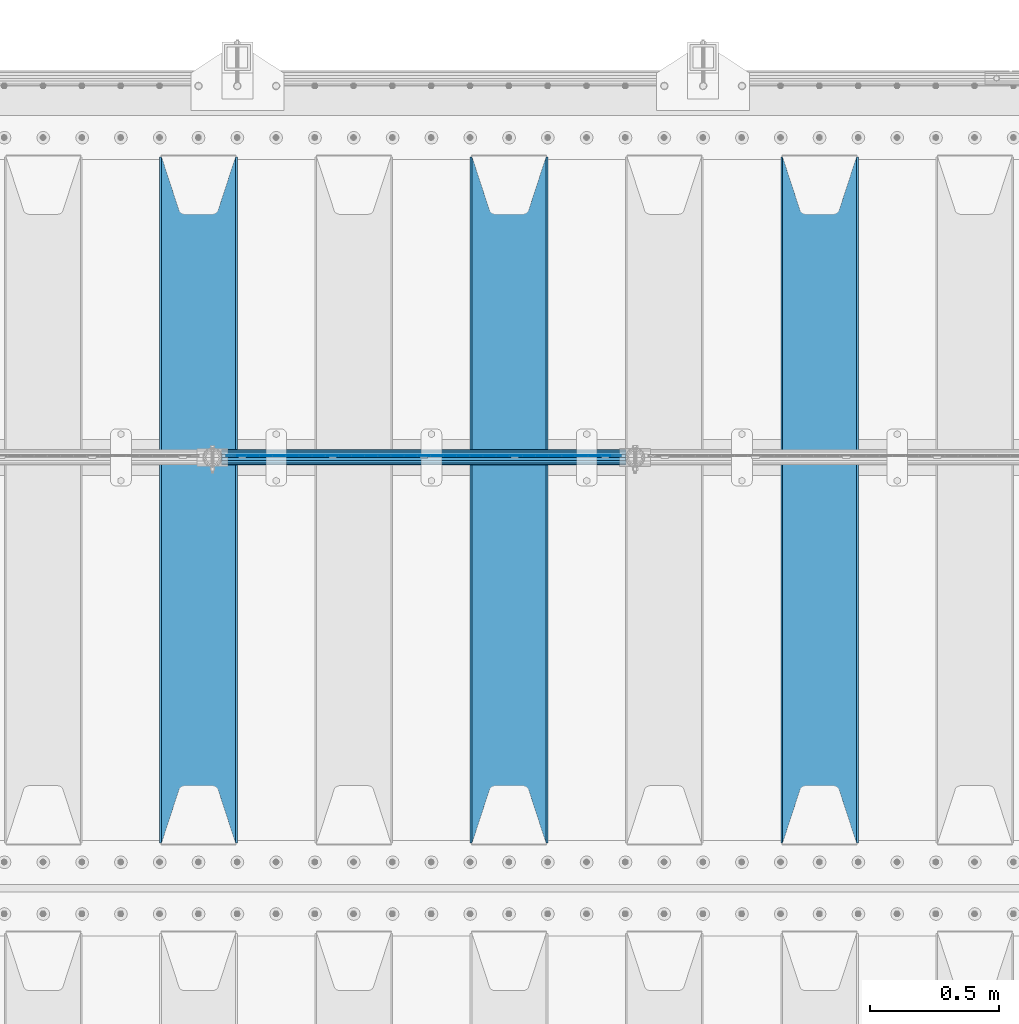
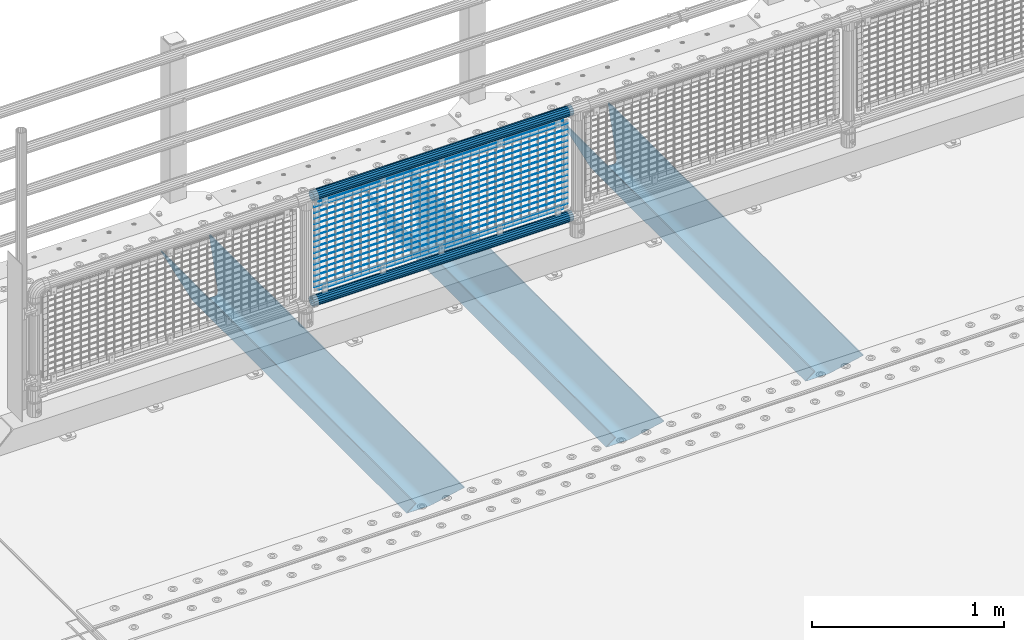
# One storey, part 129 of 270: 22 beams.
"""IFC2X3 building model written with IfcOpenShell, lengths in millimetres."""

from ifc_helpers import new_model, si_unit, frame, origin_with_axes, place, context, subcontext, project, spatial, faceted_brep, material, type_object, element, save


model = new_model("IFC2X3")

# Units and contexts
model_context = context("Model", 3, precision=1e-05, world=origin_with_axes())
body_context = subcontext(model_context, "Body", "Model", "MODEL_VIEW")
ifc_project = project(units=[si_unit("LENGTHUNIT", "METRE", prefix="MILLI"), si_unit("AREAUNIT", "SQUARE_METRE"), si_unit("VOLUMEUNIT", "CUBIC_METRE"), si_unit("MASSUNIT", "GRAM", prefix="KILO"), si_unit("TIMEUNIT", "SECOND"), si_unit("PLANEANGLEUNIT", "RADIAN"), si_unit("SOLIDANGLEUNIT", "STERADIAN"), si_unit("THERMODYNAMICTEMPERATUREUNIT", "DEGREE_CELSIUS"), si_unit("LUMINOUSINTENSITYUNIT", "LUMEN")], contexts=[model_context])

# Site, building, storey
site_placement = place(None, origin_with_axes())
site = spatial("IfcSite", under=ifc_project, at=site_placement, CompositionType="ELEMENT")
building_placement = place(site_placement, origin_with_axes())
building = spatial("IfcBuilding", under=site, at=building_placement, Name="Standard", CompositionType="ELEMENT")
storey_placement = place(building_placement, origin_with_axes())
storey = spatial("IfcBuildingStorey", under=building, at=storey_placement, Name="Undefined", CompositionType="ELEMENT", Elevation=0.0)

# Beams
ifc_material_1 = material(Name="STEEL/S355N")
beam_type_1 = type_object("IfcBeamType", PredefinedType="NOTDEFINED")
beam_1_placement = place(storey_placement, frame((4600.0, -17825.0, -115.0), z_axis=(0.0, 0.0, 1.0), x_axis=(0.0, 1.0, 0.0)))
element("IfcBeam", 1, at=beam_1_placement, inside=storey, type_object=beam_type_1, material=ifc_material_1, context=body_context, shape_type="Brep", body=[
    faceted_brep([(0.0, 150.0, 115.0), (0.0, 143.689999999999, 115.0), (2650.00000000297, 143.689999999999, 115.0), (2650.00000000297, 150.0, 115.0), (2650.00000000297, 142.059565218398, 110.000000003096), (2650.00000000297, 148.3695652184, 110.000000003096), (2441.90079219209, -80.1103600731112, -98.0992078077845), (2437.7588105432, -77.5672621345584, -102.241189456673), (2434.06523489747, -74.4080125315522, -105.934765102404), (2430.9108609509, -70.710272125576, -109.089139048974), (2428.37322971128, -66.5649389910068, -111.626770288588), (2426.51472138055, -62.0739139532889, -113.485278619323), (2425.38102192092, -57.3475956567672, -114.618978078955), (2424.99999999987, -52.5021667386536, -115.0), (2424.99999999987, 52.5021667386536, -115.0), (2425.38102192092, 57.3475956567672, -114.618978078955), (2426.51472138055, 62.0739139532889, -113.485278619323), (2428.37322971128, 66.5649389910068, -111.626770288588), (2430.9108609509, 70.710272125576, -109.089139048974), (2434.06523489747, 74.4080125315522, -105.934765102404), (2437.7588105432, 77.5672621345584, -102.241189456673), (2441.90079219209, 80.1103600731112, -98.0992078077846), (2446.38936140511, 81.9747917625791, -93.6106385947584), (2448.2494850041, 76.2713538057251, -91.7505149957729), (2444.62967112263, 74.76777986261, -95.3703288772456), (2441.28936334126, 72.7168944282894, -98.710636658607), (2438.31067330439, 70.1691124903846, -101.689326695487), (2435.76682334747, 67.1870637758839, -104.233176652398), (2433.72034654133, 63.8440531834895, -106.279653458539), (2432.22154950042, 60.222258798236, -107.778450499454), (2431.30727574265, 56.4107117849089, -108.692724257221), (2430.99999999987, 52.5031078186876, -109.0), (2430.99999999987, -52.5031078186876, -109.0), (2431.30727574265, -56.4107117849089, -108.692724257221), (2432.22154950042, -60.222258798236, -107.778450499454), (2433.72034654133, -63.8440531834895, -106.279653458539), (2435.76682334747, -67.1870637758839, -104.233176652398), (2438.31067330438, -70.1691124903846, -101.689326695487), (2441.28936334126, -72.7168944282894, -98.7106366586071), (2444.62967112263, -74.76777986261, -95.3703288772457), (2448.2494850041, -76.2713538057251, -91.7505149957729), (2650.00000000297, -142.059565218398, 110.000000003096), (2650.00000000297, -148.3695652184, 110.000000003096), (2446.38936140511, -81.9747917625791, -93.6106385947584), (2650.00000000297, -143.689999999999, 115.0), (2650.00000000297, -150.0, 115.0), (0.0, -143.689999999999, 115.0), (0.0, -150.0, 115.0), (0.0, -148.369565218261, 110.000000002672), (203.610638597431, -81.9747917625791, -93.6106385947584), (208.099207810457, -80.1103600731112, -98.0992078077845), (212.241189459342, -77.5672621345584, -102.241189456673), (215.934765105078, -74.4080125315522, -105.934765102404), (219.089139051644, -70.710272125576, -109.089139048974), (221.626770291259, -66.5649389910068, -111.626770288588), (223.485278621993, -62.0739139532889, -113.485278619323), (224.618978081628, -57.3475956567672, -114.618978078955), (225.00000000267, -52.5021667386536, -115.0), (225.00000000267, 52.5021667386536, -115.0), (224.618978081628, 57.3475956567672, -114.618978078955), (223.485278621993, 62.0739139532889, -113.485278619323), (221.626770291259, 66.5649389910068, -111.626770288588), (219.089139051644, 70.710272125576, -109.089139048974), (215.934765105078, 74.4080125315522, -105.934765102404), (212.241189459342, 77.5672621345584, -102.241189456673), (208.099207810457, 80.1103600731112, -98.0992078077846), (203.610638597431, 81.9747917625791, -93.6106385947584), (0.0, 148.369565218261, 110.000000002672), (0.0, 142.05956521826, 110.000000002672), (201.750514998446, 76.2713538057251, -91.7505149957729), (205.370328879915, 74.76777986261, -95.3703288772456), (208.710636661279, 72.7168944282894, -98.710636658607), (211.689326698157, 70.1691124903846, -101.689326695487), (214.233176655071, 67.1870637758839, -104.233176652398), (216.27965346121, 63.8440531834895, -106.279653458539), (217.778450502126, 60.222258798236, -107.778450499454), (218.692724259894, 56.4107117849089, -108.692724257221), (219.00000000267, 52.5031078186876, -109.0), (219.00000000267, -52.5031078186876, -109.0), (218.692724259894, -56.4107117849089, -108.692724257221), (217.778450502123, -60.222258798236, -107.778450499454), (216.27965346121, -63.8440531834895, -106.279653458539), (214.233176655071, -67.1870637758839, -104.233176652398), (211.689326698157, -70.1691124903846, -101.689326695487), (208.710636661279, -72.7168944282894, -98.7106366586071), (205.370328879915, -74.76777986261, -95.3703288772457), (201.750514998446, -76.2713538057251, -91.7505149957729), (0.0, -142.05956521826, 110.000000002672)], [[[0, 1, 2, 3]], [[3, 2, 4, 5]], [[6, 7, 8, 9, 10, 11, 12, 13, 14, 15, 16, 17, 18, 19, 20, 21, 22, 5, 4, 23, 24, 25, 26, 27, 28, 29, 30, 31, 32, 33, 34, 35, 36, 37, 38, 39, 40, 41, 42, 43]], [[44, 45, 42, 41]], [[46, 47, 45, 44]], [[43, 42, 45, 47, 48, 49]], [[6, 43, 49, 50]], [[7, 6, 50, 51]], [[8, 7, 51, 52]], [[9, 8, 52, 53]], [[10, 9, 53, 54]], [[11, 10, 54, 55]], [[12, 11, 55, 56]], [[13, 12, 56, 57]], [[14, 13, 57, 58]], [[15, 14, 58, 59]], [[16, 15, 59, 60]], [[17, 16, 60, 61]], [[18, 17, 61, 62]], [[19, 18, 62, 63]], [[20, 19, 63, 64]], [[21, 20, 64, 65]], [[22, 21, 65, 66]], [[0, 3, 5, 22, 66, 67]], [[1, 0, 67, 68]], [[23, 4, 2, 1, 68, 69]], [[24, 23, 69, 70]], [[25, 24, 70, 71]], [[26, 25, 71, 72]], [[27, 26, 72, 73]], [[28, 27, 73, 74]], [[29, 28, 74, 75]], [[30, 29, 75, 76]], [[31, 30, 76, 77]], [[32, 31, 77, 78]], [[33, 32, 78, 79]], [[34, 33, 79, 80]], [[35, 34, 80, 81]], [[36, 35, 81, 82]], [[37, 36, 82, 83]], [[38, 37, 83, 84]], [[39, 38, 84, 85]], [[40, 39, 85, 86]], [[46, 44, 41, 40, 86, 87]], [[47, 46, 87, 48]], [[86, 85, 84, 83, 82, 81, 80, 79, 78, 77, 76, 75, 74, 73, 72, 71, 70, 69, 68, 67, 66, 65, 64, 63, 62, 61, 60, 59, 58, 57, 56, 55, 54, 53, 52, 51, 50, 49, 48, 87]]]),
])
beam_2_placement = place(storey_placement, frame((3400.0, -17825.0, -115.0), z_axis=(0.0, 0.0, 1.0), x_axis=(0.0, 1.0, 0.0)))
element("IfcBeam", 2, at=beam_2_placement, inside=storey, type_object=beam_type_1, material=ifc_material_1, context=body_context, shape_type="Brep", body=[
    faceted_brep([(0.0, 150.0, 115.0), (0.0, 143.689999999999, 115.0), (2650.00000000297, 143.689999999999, 115.0), (2650.00000000297, 150.0, 115.0), (2650.00000000297, 142.059565218398, 110.000000003096), (2650.00000000297, 148.3695652184, 110.000000003096), (2441.90079219209, -80.1103600731112, -98.0992078077845), (2437.7588105432, -77.5672621345584, -102.241189456673), (2434.06523489747, -74.4080125315522, -105.934765102404), (2430.9108609509, -70.710272125576, -109.089139048974), (2428.37322971128, -66.5649389910068, -111.626770288588), (2426.51472138055, -62.0739139532889, -113.485278619323), (2425.38102192092, -57.3475956567672, -114.618978078955), (2424.99999999987, -52.5021667386536, -115.0), (2424.99999999987, 52.5021667386536, -115.0), (2425.38102192092, 57.3475956567672, -114.618978078955), (2426.51472138055, 62.0739139532889, -113.485278619323), (2428.37322971128, 66.5649389910068, -111.626770288588), (2430.9108609509, 70.710272125576, -109.089139048974), (2434.06523489747, 74.4080125315522, -105.934765102404), (2437.7588105432, 77.5672621345584, -102.241189456673), (2441.90079219209, 80.1103600731112, -98.0992078077846), (2446.38936140511, 81.9747917625791, -93.6106385947584), (2448.2494850041, 76.2713538057251, -91.7505149957729), (2444.62967112263, 74.76777986261, -95.3703288772456), (2441.28936334126, 72.7168944282894, -98.710636658607), (2438.31067330439, 70.1691124903846, -101.689326695487), (2435.76682334747, 67.1870637758839, -104.233176652398), (2433.72034654133, 63.8440531834895, -106.279653458539), (2432.22154950042, 60.222258798236, -107.778450499454), (2431.30727574265, 56.4107117849089, -108.692724257221), (2430.99999999987, 52.5031078186876, -109.0), (2430.99999999987, -52.5031078186876, -109.0), (2431.30727574265, -56.4107117849089, -108.692724257221), (2432.22154950042, -60.222258798236, -107.778450499454), (2433.72034654133, -63.8440531834895, -106.279653458539), (2435.76682334747, -67.1870637758839, -104.233176652398), (2438.31067330438, -70.1691124903846, -101.689326695487), (2441.28936334126, -72.7168944282894, -98.7106366586071), (2444.62967112263, -74.76777986261, -95.3703288772457), (2448.2494850041, -76.2713538057251, -91.7505149957729), (2650.00000000297, -142.059565218398, 110.000000003096), (2650.00000000297, -148.3695652184, 110.000000003096), (2446.38936140511, -81.9747917625791, -93.6106385947584), (2650.00000000297, -143.689999999999, 115.0), (2650.00000000297, -150.0, 115.0), (0.0, -143.689999999999, 115.0), (0.0, -150.0, 115.0), (0.0, -148.369565218261, 110.000000002672), (203.610638597431, -81.9747917625791, -93.6106385947584), (208.099207810457, -80.1103600731112, -98.0992078077845), (212.241189459342, -77.5672621345584, -102.241189456673), (215.934765105078, -74.4080125315522, -105.934765102404), (219.089139051644, -70.710272125576, -109.089139048974), (221.626770291259, -66.5649389910068, -111.626770288588), (223.485278621993, -62.0739139532889, -113.485278619323), (224.618978081628, -57.3475956567672, -114.618978078955), (225.00000000267, -52.5021667386536, -115.0), (225.00000000267, 52.5021667386536, -115.0), (224.618978081628, 57.3475956567672, -114.618978078955), (223.485278621993, 62.0739139532889, -113.485278619323), (221.626770291259, 66.5649389910068, -111.626770288588), (219.089139051644, 70.710272125576, -109.089139048974), (215.934765105078, 74.4080125315522, -105.934765102404), (212.241189459342, 77.5672621345584, -102.241189456673), (208.099207810457, 80.1103600731112, -98.0992078077846), (203.610638597431, 81.9747917625791, -93.6106385947584), (0.0, 148.369565218261, 110.000000002672), (0.0, 142.05956521826, 110.000000002672), (201.750514998446, 76.2713538057251, -91.7505149957729), (205.370328879915, 74.76777986261, -95.3703288772456), (208.710636661279, 72.7168944282894, -98.710636658607), (211.689326698157, 70.1691124903846, -101.689326695487), (214.233176655071, 67.1870637758839, -104.233176652398), (216.27965346121, 63.8440531834895, -106.279653458539), (217.778450502126, 60.222258798236, -107.778450499454), (218.692724259894, 56.4107117849089, -108.692724257221), (219.00000000267, 52.5031078186876, -109.0), (219.00000000267, -52.5031078186876, -109.0), (218.692724259894, -56.4107117849089, -108.692724257221), (217.778450502123, -60.222258798236, -107.778450499454), (216.27965346121, -63.8440531834895, -106.279653458539), (214.233176655071, -67.1870637758839, -104.233176652398), (211.689326698157, -70.1691124903846, -101.689326695487), (208.710636661279, -72.7168944282894, -98.7106366586071), (205.370328879915, -74.76777986261, -95.3703288772457), (201.750514998446, -76.2713538057251, -91.7505149957729), (0.0, -142.05956521826, 110.000000002672)], [[[0, 1, 2, 3]], [[3, 2, 4, 5]], [[6, 7, 8, 9, 10, 11, 12, 13, 14, 15, 16, 17, 18, 19, 20, 21, 22, 5, 4, 23, 24, 25, 26, 27, 28, 29, 30, 31, 32, 33, 34, 35, 36, 37, 38, 39, 40, 41, 42, 43]], [[44, 45, 42, 41]], [[46, 47, 45, 44]], [[43, 42, 45, 47, 48, 49]], [[6, 43, 49, 50]], [[7, 6, 50, 51]], [[8, 7, 51, 52]], [[9, 8, 52, 53]], [[10, 9, 53, 54]], [[11, 10, 54, 55]], [[12, 11, 55, 56]], [[13, 12, 56, 57]], [[14, 13, 57, 58]], [[15, 14, 58, 59]], [[16, 15, 59, 60]], [[17, 16, 60, 61]], [[18, 17, 61, 62]], [[19, 18, 62, 63]], [[20, 19, 63, 64]], [[21, 20, 64, 65]], [[22, 21, 65, 66]], [[0, 3, 5, 22, 66, 67]], [[1, 0, 67, 68]], [[23, 4, 2, 1, 68, 69]], [[24, 23, 69, 70]], [[25, 24, 70, 71]], [[26, 25, 71, 72]], [[27, 26, 72, 73]], [[28, 27, 73, 74]], [[29, 28, 74, 75]], [[30, 29, 75, 76]], [[31, 30, 76, 77]], [[32, 31, 77, 78]], [[33, 32, 78, 79]], [[34, 33, 79, 80]], [[35, 34, 80, 81]], [[36, 35, 81, 82]], [[37, 36, 82, 83]], [[38, 37, 83, 84]], [[39, 38, 84, 85]], [[40, 39, 85, 86]], [[46, 44, 41, 40, 86, 87]], [[47, 46, 87, 48]], [[86, 85, 84, 83, 82, 81, 80, 79, 78, 77, 76, 75, 74, 73, 72, 71, 70, 69, 68, 67, 66, 65, 64, 63, 62, 61, 60, 59, 58, 57, 56, 55, 54, 53, 52, 51, 50, 49, 48, 87]]]),
])
beam_3_placement = place(storey_placement, frame((2200.0, -17825.0, -115.0), z_axis=(0.0, 0.0, 1.0), x_axis=(0.0, 1.0, 0.0)))
element("IfcBeam", 3, at=beam_3_placement, inside=storey, type_object=beam_type_1, material=ifc_material_1, context=body_context, shape_type="Brep", body=[
    faceted_brep([(0.0, 150.0, 115.0), (0.0, 143.689999999999, 115.0), (2650.00000000297, 143.689999999999, 115.0), (2650.00000000297, 150.0, 115.0), (2650.00000000297, 142.059565218398, 110.000000003096), (2650.00000000297, 148.3695652184, 110.000000003096), (2441.90079219209, -80.1103600731112, -98.0992078077845), (2437.7588105432, -77.5672621345584, -102.241189456673), (2434.06523489747, -74.4080125315522, -105.934765102404), (2430.9108609509, -70.710272125576, -109.089139048974), (2428.37322971128, -66.5649389910068, -111.626770288588), (2426.51472138055, -62.0739139532889, -113.485278619323), (2425.38102192092, -57.3475956567672, -114.618978078955), (2424.99999999987, -52.5021667386536, -115.0), (2424.99999999987, 52.5021667386536, -115.0), (2425.38102192092, 57.3475956567672, -114.618978078955), (2426.51472138055, 62.0739139532889, -113.485278619323), (2428.37322971128, 66.5649389910068, -111.626770288588), (2430.9108609509, 70.710272125576, -109.089139048974), (2434.06523489747, 74.4080125315522, -105.934765102404), (2437.7588105432, 77.5672621345584, -102.241189456673), (2441.90079219209, 80.1103600731112, -98.0992078077846), (2446.38936140511, 81.9747917625791, -93.6106385947584), (2448.2494850041, 76.2713538057251, -91.7505149957729), (2444.62967112263, 74.76777986261, -95.3703288772456), (2441.28936334126, 72.7168944282894, -98.710636658607), (2438.31067330439, 70.1691124903846, -101.689326695487), (2435.76682334747, 67.1870637758839, -104.233176652398), (2433.72034654133, 63.8440531834895, -106.279653458539), (2432.22154950042, 60.222258798236, -107.778450499454), (2431.30727574265, 56.4107117849089, -108.692724257221), (2430.99999999987, 52.5031078186876, -109.0), (2430.99999999987, -52.5031078186876, -109.0), (2431.30727574265, -56.4107117849089, -108.692724257221), (2432.22154950042, -60.222258798236, -107.778450499454), (2433.72034654133, -63.8440531834895, -106.279653458539), (2435.76682334747, -67.1870637758839, -104.233176652398), (2438.31067330438, -70.1691124903846, -101.689326695487), (2441.28936334126, -72.7168944282894, -98.7106366586071), (2444.62967112263, -74.76777986261, -95.3703288772457), (2448.2494850041, -76.2713538057251, -91.7505149957729), (2650.00000000297, -142.059565218398, 110.000000003096), (2650.00000000297, -148.3695652184, 110.000000003096), (2446.38936140511, -81.9747917625791, -93.6106385947584), (2650.00000000297, -143.689999999999, 115.0), (2650.00000000297, -150.0, 115.0), (0.0, -143.689999999999, 115.0), (0.0, -150.0, 115.0), (0.0, -148.369565218261, 110.000000002672), (203.610638597431, -81.9747917625791, -93.6106385947584), (208.099207810457, -80.1103600731112, -98.0992078077845), (212.241189459342, -77.5672621345584, -102.241189456673), (215.934765105078, -74.4080125315522, -105.934765102404), (219.089139051644, -70.710272125576, -109.089139048974), (221.626770291259, -66.5649389910068, -111.626770288588), (223.485278621993, -62.0739139532889, -113.485278619323), (224.618978081628, -57.3475956567672, -114.618978078955), (225.00000000267, -52.5021667386536, -115.0), (225.00000000267, 52.5021667386536, -115.0), (224.618978081628, 57.3475956567672, -114.618978078955), (223.485278621993, 62.0739139532889, -113.485278619323), (221.626770291259, 66.5649389910068, -111.626770288588), (219.089139051644, 70.710272125576, -109.089139048974), (215.934765105078, 74.4080125315522, -105.934765102404), (212.241189459342, 77.5672621345584, -102.241189456673), (208.099207810457, 80.1103600731112, -98.0992078077846), (203.610638597431, 81.9747917625791, -93.6106385947584), (0.0, 148.369565218261, 110.000000002672), (0.0, 142.05956521826, 110.000000002672), (201.750514998446, 76.2713538057251, -91.7505149957729), (205.370328879915, 74.76777986261, -95.3703288772456), (208.710636661279, 72.7168944282894, -98.710636658607), (211.689326698157, 70.1691124903846, -101.689326695487), (214.233176655071, 67.1870637758839, -104.233176652398), (216.27965346121, 63.8440531834895, -106.279653458539), (217.778450502126, 60.222258798236, -107.778450499454), (218.692724259894, 56.4107117849089, -108.692724257221), (219.00000000267, 52.5031078186876, -109.0), (219.00000000267, -52.5031078186876, -109.0), (218.692724259894, -56.4107117849089, -108.692724257221), (217.778450502123, -60.222258798236, -107.778450499454), (216.27965346121, -63.8440531834895, -106.279653458539), (214.233176655071, -67.1870637758839, -104.233176652398), (211.689326698157, -70.1691124903846, -101.689326695487), (208.710636661279, -72.7168944282894, -98.7106366586071), (205.370328879915, -74.76777986261, -95.3703288772457), (201.750514998446, -76.2713538057251, -91.7505149957729), (0.0, -142.05956521826, 110.000000002672)], [[[0, 1, 2, 3]], [[3, 2, 4, 5]], [[6, 7, 8, 9, 10, 11, 12, 13, 14, 15, 16, 17, 18, 19, 20, 21, 22, 5, 4, 23, 24, 25, 26, 27, 28, 29, 30, 31, 32, 33, 34, 35, 36, 37, 38, 39, 40, 41, 42, 43]], [[44, 45, 42, 41]], [[46, 47, 45, 44]], [[43, 42, 45, 47, 48, 49]], [[6, 43, 49, 50]], [[7, 6, 50, 51]], [[8, 7, 51, 52]], [[9, 8, 52, 53]], [[10, 9, 53, 54]], [[11, 10, 54, 55]], [[12, 11, 55, 56]], [[13, 12, 56, 57]], [[14, 13, 57, 58]], [[15, 14, 58, 59]], [[16, 15, 59, 60]], [[17, 16, 60, 61]], [[18, 17, 61, 62]], [[19, 18, 62, 63]], [[20, 19, 63, 64]], [[21, 20, 64, 65]], [[22, 21, 65, 66]], [[0, 3, 5, 22, 66, 67]], [[1, 0, 67, 68]], [[23, 4, 2, 1, 68, 69]], [[24, 23, 69, 70]], [[25, 24, 70, 71]], [[26, 25, 71, 72]], [[27, 26, 72, 73]], [[28, 27, 73, 74]], [[29, 28, 74, 75]], [[30, 29, 75, 76]], [[31, 30, 76, 77]], [[32, 31, 77, 78]], [[33, 32, 78, 79]], [[34, 33, 79, 80]], [[35, 34, 80, 81]], [[36, 35, 81, 82]], [[37, 36, 82, 83]], [[38, 37, 83, 84]], [[39, 38, 84, 85]], [[40, 39, 85, 86]], [[46, 44, 41, 40, 86, 87]], [[47, 46, 87, 48]], [[86, 85, 84, 83, 82, 81, 80, 79, 78, 77, 76, 75, 74, 73, 72, 71, 70, 69, 68, 67, 66, 65, 64, 63, 62, 61, 60, 59, 58, 57, 56, 55, 54, 53, 52, 51, 50, 49, 48, 87]]]),
])
ifc_material_2 = material(Name="Misc_Undefined")
beam_type_2 = type_object("IfcBeamType", Name="D3", PredefinedType="NOTDEFINED")
for number, where, z_axis, x_axis in (
    (4, (2309.0, -16329.5, 851.596999999999), (0.0, 0.0, 1.0), (1.0, 0.0, 0.0)),
    (5, (2309.0, -16329.5, 669.452), (0.0, 0.0, 1.0), (1.0, 0.0, 0.0)),
    (6, (2309.0, -16329.5, 523.736), (0.0, 0.0, 1.0), (1.0, 0.0, 0.0)),
    (7, (2309.0, -16329.5, 487.307), (0.0, 0.0, 1.0), (1.0, 0.0, 0.0)),
    (8, (2309.0, -16329.5, 705.881), (0.0, 0.0, 1.0), (1.0, 0.0, 0.0)),
    (9, (2309.0, -16329.5, 596.594), (0.0, 0.0, 1.0), (1.0, 0.0, 0.0)),
    (10, (2309.0, -16329.5, 450.878), (0.0, 0.0, 1.0), (1.0, 0.0, 0.0)),
    (11, (2309.0, -16329.5, 815.167999999999), (0.0, 0.0, 1.0), (1.0, 0.0, 0.0)),
    (12, (2309.0, -16329.5, 888.025999999999), (0.0, 0.0, 1.0), (1.0, 0.0, 0.0)),
    (13, (2309.0, -16329.5, 778.738999999999), (0.0, 0.0, 1.0), (1.0, 0.0, 0.0)),
    (14, (2309.0, -16329.5, 742.309999999999), (0.0, 0.0, 1.0), (1.0, 0.0, 0.0)),
    (15, (2309.0, -16329.5, 633.023), (0.0, 0.0, 1.0), (1.0, 0.0, 0.0)),
    (16, (2309.0, -16329.5, 560.165), (0.0, 0.0, 1.0), (1.0, 0.0, 0.0)),
    (17, (2309.0, -16329.5, 414.449), (0.0, 0.0, 1.0), (1.0, 0.0, 0.0)),
):
    element("IfcBeam", number, at=place(storey_placement, frame(where, z_axis=z_axis, x_axis=x_axis)), inside=storey, type_object=beam_type_2, material=ifc_material_2, ObjectType="D3", context=body_context, shape_type="Brep", body=[
        faceted_brep([(0.0, -1.5, 0.0), (0.0, -0.75, -1.29903810567669), (1523.0, -0.75, -1.29903810567669), (1523.0, -1.5, 0.0), (0.0, 0.75, -1.29903810567669), (1523.0, 0.75, -1.29903810567669), (0.0, 1.5, 0.0), (1523.0, 1.5, 0.0), (0.0, 0.75, 1.29903810567669), (1523.0, 0.75, 1.29903810567669), (0.0, -0.75, 1.29903810567669), (1523.0, -0.75, 1.29903810567669)], [[[0, 1, 2, 3]], [[1, 4, 5, 2]], [[4, 6, 7, 5]], [[6, 8, 9, 7]], [[8, 10, 11, 9]], [[10, 0, 3, 11]], [[5, 7, 9, 11, 3, 2]], [[10, 8, 6, 4, 1, 0]]]),
    ])
beam_4_placement = place(storey_placement, frame((2334.0, -16329.5, 353.02), z_axis=(0.0, 0.0, 1.0), x_axis=(1.0, 0.0, 0.0)))
element("IfcBeam", 18, at=beam_4_placement, inside=storey, type_object=beam_type_2, material=ifc_material_2, ObjectType="D3", context=body_context, shape_type="Brep", body=[
    faceted_brep([(0.0, -1.5, 0.0), (0.0, -0.75, -1.29903810567669), (1473.0, -0.75, -1.29903810567669), (1473.0, -1.5, 0.0), (0.0, 0.75, -1.29903810567669), (1473.0, 0.75, -1.29903810567663), (0.0, 1.5, 0.0), (1473.0, 1.5, 0.0), (0.0, 0.75, 1.29903810567669), (1473.0, 0.75, 1.29903810567669), (0.0, -0.75, 1.29903810567669), (1473.0, -0.75, 1.29903810567669)], [[[0, 1, 2, 3]], [[1, 4, 5, 2]], [[4, 6, 7, 5]], [[6, 8, 9, 7]], [[8, 10, 11, 9]], [[10, 0, 3, 11]], [[5, 7, 9, 11, 3, 2]], [[10, 8, 6, 4, 1, 0]]]),
])
beam_5_placement = place(storey_placement, frame((2309.0, -16329.5, 378.02), z_axis=(0.0, 0.0, 1.0), x_axis=(1.0, 0.0, 0.0)))
element("IfcBeam", 19, at=beam_5_placement, inside=storey, type_object=beam_type_2, material=ifc_material_2, ObjectType="D3", context=body_context, shape_type="Brep", body=[
    faceted_brep([(0.0, -1.5, 0.0), (0.0, -0.75, -1.29903810567669), (1523.0, -0.75, -1.29903810567669), (1523.0, -1.5, 0.0), (0.0, 0.75, -1.29903810567669), (1523.0, 0.75, -1.29903810567669), (0.0, 1.5, 0.0), (1523.0, 1.5, 0.0), (0.0, 0.75, 1.29903810567669), (1523.0, 0.75, 1.29903810567669), (0.0, -0.75, 1.29903810567669), (1523.0, -0.75, 1.29903810567669)], [[[0, 1, 2, 3]], [[1, 4, 5, 2]], [[4, 6, 7, 5]], [[6, 8, 9, 7]], [[8, 10, 11, 9]], [[10, 0, 3, 11]], [[5, 7, 9, 11, 3, 2]], [[10, 8, 6, 4, 1, 0]]]),
])
beam_6_placement = place(storey_placement, frame((2334.0, -16329.5, 913.02), z_axis=(0.0, 0.0, 1.0), x_axis=(1.0, 0.0, 0.0)))
element("IfcBeam", 20, at=beam_6_placement, inside=storey, type_object=beam_type_2, material=ifc_material_2, ObjectType="D3", context=body_context, shape_type="Brep", body=[
    faceted_brep([(0.0, -1.5, 0.0), (0.0, -0.75, -1.29903810567669), (1473.0, -0.75, -1.29903810567669), (1473.0, -1.5, 0.0), (0.0, 0.75, -1.29903810567669), (1473.0, 0.75, -1.29903810567663), (0.0, 1.5, 0.0), (1473.0, 1.5, 0.0), (0.0, 0.75, 1.29903810567669), (1473.0, 0.75, 1.29903810567669), (0.0, -0.75, 1.29903810567669), (1473.0, -0.75, 1.29903810567669)], [[[0, 1, 2, 3]], [[1, 4, 5, 2]], [[4, 6, 7, 5]], [[6, 8, 9, 7]], [[8, 10, 11, 9]], [[10, 0, 3, 11]], [[5, 7, 9, 11, 3, 2]], [[10, 8, 6, 4, 1, 0]]]),
])
ifc_material_3 = material()
beam_type_3 = type_object("IfcBeamType", PredefinedType="NOTDEFINED")
beam_7_placement = place(storey_placement, frame((2288.85, -16335.5, 969.849999999999), z_axis=(0.0, 0.0, 1.0), x_axis=(1.0, 0.0, 0.0)))
element("IfcBeam", 21, at=beam_7_placement, inside=storey, type_object=beam_type_3, material=ifc_material_3, context=body_context, shape_type="Brep", body=[
    faceted_brep([(0.0, -25.3500000000004, 0.0), (0.0, -23.4203461491616, 9.70102501045403), (1563.0, -23.4203461491616, 9.70102501045506), (1563.0, -25.3500000000004, 0.0), (0.0, -17.9251569030785, 17.9251569030785), (1563.0, -17.9251569030785, 17.925156903079), (0.0, -9.70102501045585, 23.4203461491597), (1563.0, -9.70102501045585, 23.4203461491611), (0.0, 0.0, 25.3499999999985), (1563.0, 0.0, 25.35), (0.0, 9.70102501045585, 23.4203461491597), (1563.0, 9.70102501045585, 23.4203461491611), (0.0, 17.9251569030785, 17.9251569030785), (1563.0, 17.9251569030785, 17.925156903079), (0.0, 23.4203461491616, 9.70102501045403), (1563.0, 23.4203461491616, 9.70102501045506), (0.0, 25.3500000000004, 0.0), (1563.0, 25.3500000000004, 0.0), (0.0, 23.4203461491616, -9.70102501045403), (1563.0, 23.4203461491616, -9.70102501045506), (0.0, 17.9251569030785, -17.9251569030785), (1563.0, 17.9251569030785, -17.925156903079), (0.0, 9.70102501045585, -23.4203461491597), (1563.0, 9.70102501045585, -23.4203461491611), (0.0, 0.0, -25.3499999999985), (1563.0, 0.0, -25.35), (0.0, -9.70102501045585, -23.4203461491597), (1563.0, -9.70102501045585, -23.4203461491611), (0.0, -17.9251569030785, -17.9251569030785), (1563.0, -17.9251569030785, -17.925156903079), (0.0, -23.4203461491616, -9.70102501045403), (1563.0, -23.4203461491616, -9.70102501045506), (0.0, -30.1499999999996, 0.0), (0.0, -27.8549679052157, -11.5379054858058), (1563.0, -27.8549679052157, -11.5379054858075), (1563.0, -30.1499999999996, 0.0), (0.0, -21.3192694527752, -21.3192694527752), (1563.0, -21.3192694527752, -21.3192694527744), (0.0, -11.5379054858076, -27.8549679052157), (1563.0, -11.5379054858076, -27.8549679052153), (0.0, 0.0, -30.1500000000015), (1563.0, 0.0, -30.15), (0.0, 11.5379054858076, -27.8549679052157), (1563.0, 11.5379054858076, -27.8549679052153), (0.0, 21.3192694527752, -21.3192694527752), (1563.0, 21.3192694527752, -21.3192694527744), (0.0, 27.8549679052157, -11.5379054858058), (1563.0, 27.8549679052157, -11.5379054858074), (0.0, 30.1499999999996, 0.0), (1563.0, 30.1499999999996, 0.0), (0.0, 27.8549679052157, 11.5379054858058), (1563.0, 27.8549679052157, 11.5379054858074), (0.0, 21.3192694527752, 21.3192694527752), (1563.0, 21.3192694527752, 21.3192694527744), (0.0, 11.5379054858076, 27.8549679052157), (1563.0, 11.5379054858076, 27.8549679052153), (0.0, 0.0, 30.1500000000015), (1563.0, 0.0, 30.15), (0.0, -11.5379054858076, 27.8549679052157), (1563.0, -11.5379054858076, 27.8549679052153), (0.0, -21.3192694527752, 21.3192694527752), (1563.0, -21.3192694527752, 21.3192694527744), (0.0, -27.8549679052157, 11.5379054858058), (1563.0, -27.8549679052157, 11.5379054858074)], [[[0, 1, 2, 3]], [[1, 4, 5, 2]], [[4, 6, 7, 5]], [[6, 8, 9, 7]], [[8, 10, 11, 9]], [[10, 12, 13, 11]], [[12, 14, 15, 13]], [[14, 16, 17, 15]], [[16, 18, 19, 17]], [[18, 20, 21, 19]], [[20, 22, 23, 21]], [[22, 24, 25, 23]], [[24, 26, 27, 25]], [[26, 28, 29, 27]], [[28, 30, 31, 29]], [[30, 0, 3, 31]], [[32, 33, 34, 35]], [[33, 36, 37, 34]], [[36, 38, 39, 37]], [[38, 40, 41, 39]], [[40, 42, 43, 41]], [[42, 44, 45, 43]], [[44, 46, 47, 45]], [[46, 48, 49, 47]], [[48, 50, 51, 49]], [[50, 52, 53, 51]], [[52, 54, 55, 53]], [[54, 56, 57, 55]], [[56, 58, 59, 57]], [[58, 60, 61, 59]], [[60, 62, 63, 61]], [[62, 32, 35, 63]], [[37, 39, 41, 43, 45, 47, 49, 51, 53, 55, 57, 59, 61, 63, 35, 34], [5, 7, 9, 11, 13, 15, 17, 19, 21, 23, 25, 27, 29, 31, 3, 2]], [[62, 60, 58, 56, 54, 52, 50, 48, 46, 44, 42, 40, 38, 36, 33, 32], [30, 28, 26, 24, 22, 20, 18, 16, 14, 12, 10, 8, 6, 4, 1, 0]]]),
])
beam_8_placement = place(storey_placement, frame((2288.85000000001, -16335.5, 298.170000000001), z_axis=(0.0, 0.0, 1.0), x_axis=(1.0, 0.0, 0.0)))
element("IfcBeam", 22, at=beam_8_placement, inside=storey, type_object=beam_type_3, material=ifc_material_3, context=body_context, shape_type="Brep", body=[
    faceted_brep([(0.0, -25.3500000000004, 0.0), (0.0, -23.4203461491616, 9.70102501045403), (1563.0, -23.4203461491616, 9.70102501045506), (1563.0, -25.3500000000004, 0.0), (0.0, -17.9251569030785, 17.9251569030785), (1563.0, -17.9251569030785, 17.925156903079), (0.0, -9.70102501045585, 23.4203461491597), (1563.0, -9.70102501045585, 23.4203461491611), (0.0, 0.0, 25.3499999999985), (1563.0, 0.0, 25.35), (0.0, 9.70102501045585, 23.4203461491597), (1563.0, 9.70102501045585, 23.4203461491611), (0.0, 17.9251569030785, 17.9251569030785), (1563.0, 17.9251569030785, 17.925156903079), (0.0, 23.4203461491616, 9.70102501045403), (1563.0, 23.4203461491616, 9.70102501045506), (0.0, 25.3500000000004, 0.0), (1563.0, 25.3500000000004, 0.0), (0.0, 23.4203461491616, -9.70102501045403), (1563.0, 23.4203461491616, -9.70102501045506), (0.0, 17.9251569030785, -17.9251569030785), (1563.0, 17.9251569030785, -17.925156903079), (0.0, 9.70102501045585, -23.4203461491597), (1563.0, 9.70102501045585, -23.4203461491611), (0.0, 0.0, -25.3499999999985), (1563.0, 0.0, -25.35), (0.0, -9.70102501045585, -23.4203461491597), (1563.0, -9.70102501045585, -23.4203461491611), (0.0, -17.9251569030785, -17.9251569030785), (1563.0, -17.9251569030785, -17.925156903079), (0.0, -23.4203461491616, -9.70102501045403), (1563.0, -23.4203461491616, -9.70102501045506), (0.0, -30.1499999999996, 0.0), (0.0, -27.8549679052157, -11.5379054858058), (1563.0, -27.8549679052157, -11.5379054858075), (1563.0, -30.1499999999996, 0.0), (0.0, -21.3192694527752, -21.3192694527752), (1563.0, -21.3192694527752, -21.3192694527744), (0.0, -11.5379054858076, -27.8549679052157), (1563.0, -11.5379054858076, -27.8549679052153), (0.0, 0.0, -30.1500000000015), (1563.0, 0.0, -30.15), (0.0, 11.5379054858076, -27.8549679052157), (1563.0, 11.5379054858076, -27.8549679052153), (0.0, 21.3192694527752, -21.3192694527752), (1563.0, 21.3192694527752, -21.3192694527744), (0.0, 27.8549679052157, -11.5379054858058), (1563.0, 27.8549679052157, -11.5379054858074), (0.0, 30.1499999999996, 0.0), (1563.0, 30.1499999999996, 0.0), (0.0, 27.8549679052157, 11.5379054858058), (1563.0, 27.8549679052157, 11.5379054858074), (0.0, 21.3192694527752, 21.3192694527752), (1563.0, 21.3192694527752, 21.3192694527744), (0.0, 11.5379054858076, 27.8549679052157), (1563.0, 11.5379054858076, 27.8549679052153), (0.0, 0.0, 30.1500000000015), (1563.0, 0.0, 30.15), (0.0, -11.5379054858076, 27.8549679052157), (1563.0, -11.5379054858076, 27.8549679052153), (0.0, -21.3192694527752, 21.3192694527752), (1563.0, -21.3192694527752, 21.3192694527744), (0.0, -27.8549679052157, 11.5379054858058), (1563.0, -27.8549679052157, 11.5379054858074)], [[[0, 1, 2, 3]], [[1, 4, 5, 2]], [[4, 6, 7, 5]], [[6, 8, 9, 7]], [[8, 10, 11, 9]], [[10, 12, 13, 11]], [[12, 14, 15, 13]], [[14, 16, 17, 15]], [[16, 18, 19, 17]], [[18, 20, 21, 19]], [[20, 22, 23, 21]], [[22, 24, 25, 23]], [[24, 26, 27, 25]], [[26, 28, 29, 27]], [[28, 30, 31, 29]], [[30, 0, 3, 31]], [[32, 33, 34, 35]], [[33, 36, 37, 34]], [[36, 38, 39, 37]], [[38, 40, 41, 39]], [[40, 42, 43, 41]], [[42, 44, 45, 43]], [[44, 46, 47, 45]], [[46, 48, 49, 47]], [[48, 50, 51, 49]], [[50, 52, 53, 51]], [[52, 54, 55, 53]], [[54, 56, 57, 55]], [[56, 58, 59, 57]], [[58, 60, 61, 59]], [[60, 62, 63, 61]], [[62, 32, 35, 63]], [[37, 39, 41, 43, 45, 47, 49, 51, 53, 55, 57, 59, 61, 63, 35, 34], [5, 7, 9, 11, 13, 15, 17, 19, 21, 23, 25, 27, 29, 31, 3, 2]], [[62, 60, 58, 56, 54, 52, 50, 48, 46, 44, 42, 40, 38, 36, 33, 32], [30, 28, 26, 24, 22, 20, 18, 16, 14, 12, 10, 8, 6, 4, 1, 0]]]),
])

save(model, "model.ifc")
